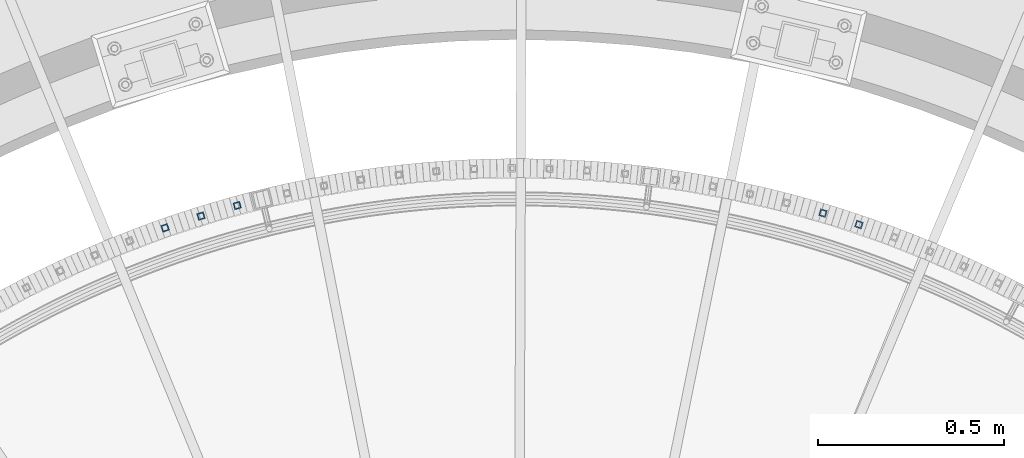
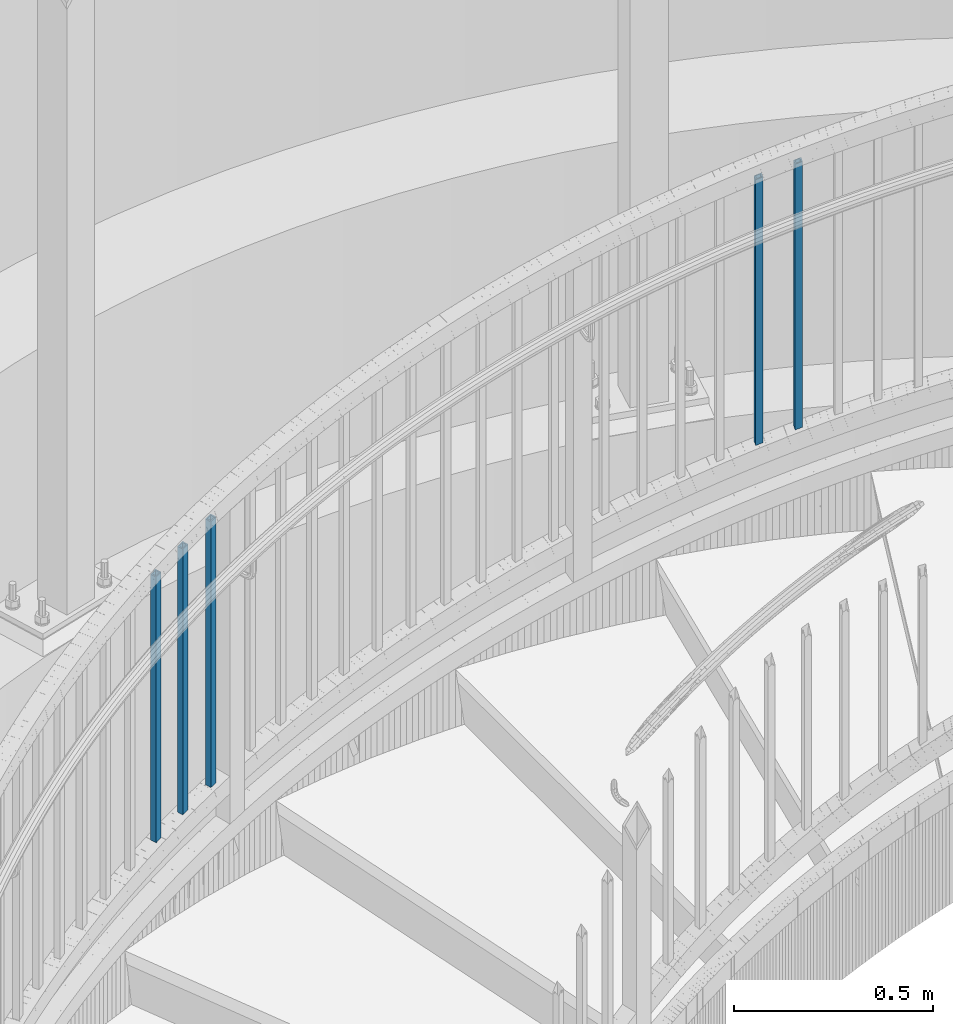
# One storey, part 265 of 975: 5 columns.
"""IFC2X3 building model written with IfcOpenShell, lengths in millimetres."""

from ifc_helpers import new_model, si_unit, frame, origin_with_axes, place, context, subcontext, project, spatial, faceted_brep, material, type_object, element, save


model = new_model("IFC2X3")

# Units and contexts
model_context = context("Model", 3, precision=1e-05, world=origin_with_axes())
body_context = subcontext(model_context, "Body", "Model", "MODEL_VIEW")
ifc_project = project(units=[si_unit("LENGTHUNIT", "METRE", prefix="MILLI"), si_unit("AREAUNIT", "SQUARE_METRE"), si_unit("VOLUMEUNIT", "CUBIC_METRE"), si_unit("MASSUNIT", "GRAM", prefix="KILO"), si_unit("TIMEUNIT", "SECOND"), si_unit("PLANEANGLEUNIT", "RADIAN"), si_unit("SOLIDANGLEUNIT", "STERADIAN"), si_unit("THERMODYNAMICTEMPERATUREUNIT", "DEGREE_CELSIUS"), si_unit("LUMINOUSINTENSITYUNIT", "LUMEN")], contexts=[model_context])

# Site, building, storey
site_placement = place(None, origin_with_axes())
site = spatial("IfcSite", under=ifc_project, at=site_placement, CompositionType="ELEMENT")
building_placement = place(site_placement, origin_with_axes())
building = spatial("IfcBuilding", under=site, at=building_placement, Name="Undefined", CompositionType="ELEMENT")
storey_placement = place(building_placement, origin_with_axes())
storey = spatial("IfcBuildingStorey", under=building, at=storey_placement, Name="Undefined", CompositionType="ELEMENT", Elevation=0.0)

# Columns
ifc_material = material()
column_type = type_object("IfcColumnType", Name="HSS3/4X3/4X.120_TUBES", PredefinedType="NOTDEFINED")
for number, where, z_axis, x_axis, name in (
    (1, (35654.4026776705, 6122.27282761552, 1517.2571643963), (0.320310531852098, 0.947312600562574, 0.0), (0.0, 0.0, 1.0), "PICKET"),
    (2, (35557.6184121575, 6153.12340589558, 1484.9118523963), (0.286586514898605, 0.958054366661032, 0.0), (0.0, 0.0, 1.0), "PICKET"),
    (3, (33982.2598900702, 6173.47054878241, 977.698668348244), (-0.262962334039454, 0.964806100144751, 0.0), (0.0, 0.0, 1.0), "PICKET"),
    (4, (33884.7111877214, 6145.11545947229, 945.353356348244), (-0.296940077034021, 0.954896115109403, 0.0), (0.0, 0.0, 1.0), "PICKET"),
    (5, (33788.2270114481, 6113.32608784293, 913.008044348244), (-0.330545846065659, 0.943789936187464, 0.0), (0.0, 0.0, 1.0), "PICKET"),
):
    element("IfcColumn", number, at=place(storey_placement, frame(where, z_axis=z_axis, x_axis=x_axis)), inside=storey, type_object=column_type, material=ifc_material, Name=name, ObjectType="HSS3/4X3/4X.120_TUBES", context=body_context, shape_type="Brep", body=[
        faceted_brep([(48.9778304891588, 6.35000000000036, -6.34999999999854), (44.9444858438005, -6.35000000000582, -6.34999999999127), (858.946568247068, -6.35000000000582, -6.34999999999127), (863.063419332087, 6.35000000000036, -6.34999999999854), (44.9444858438051, -6.35000000000036, 6.35000000000582), (858.946568247072, -6.35000000000036, 6.35000000000582), (48.9778304891634, 6.350000000004, 6.34999999999854), (863.063419332091, 6.350000000004, 6.34999999999854), (49.9861666504976, 9.52499999999964, -9.52500000000146), (49.9861666505039, 9.52500000000691, 9.52499999999418), (864.092632103347, 9.52500000000691, 9.52499999999418), (864.09263210334, 9.52499999999964, -9.52500000000146), (43.9361496824667, -9.52500000000146, 9.52500000001601), (857.917355475819, -9.52500000000146, 9.52500000001601), (43.9361496824599, -9.52500000000691, -9.52499999997963), (857.917355475812, -9.52500000000691, -9.52499999997963)], [[[0, 1, 2, 3]], [[1, 4, 5, 2]], [[4, 6, 7, 5]], [[6, 0, 3, 7]], [[8, 9, 10, 11]], [[9, 12, 13, 10]], [[12, 14, 15, 13]], [[14, 8, 11, 15]], [[13, 15, 11, 10], [5, 7, 3, 2]], [[14, 12, 9, 8], [6, 4, 1, 0]]]),
    ])

save(model, "model.ifc")
